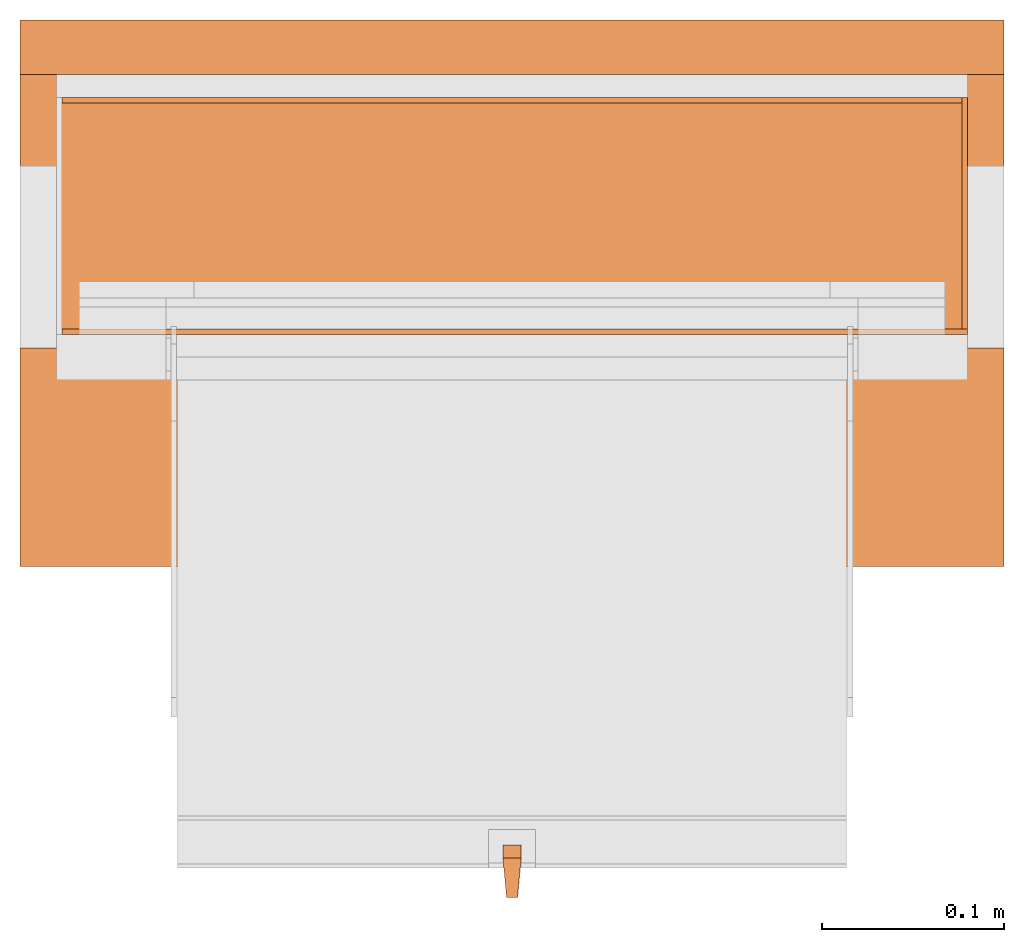
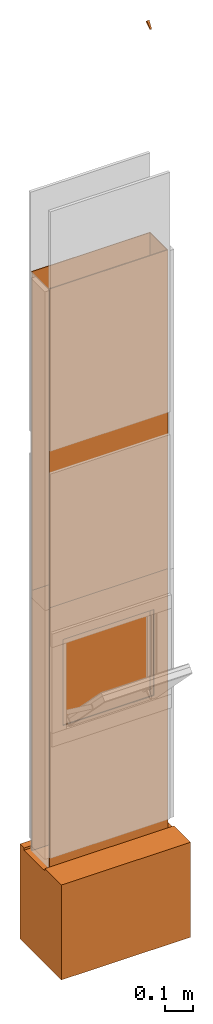
# One storey, part 3 of 3: 8 proxies, 1 opening.
"""IFC2X3 building model written with IfcOpenShell, lengths in metres."""

from ifc_helpers import new_model, entity, si_unit, converted_unit, derived_unit, money_unit, direction, frame, origin_with_axes, origin_2d_with_axis, place, context, subcontext, project, spatial, polyline, rectangle, outline, extrude, boolean, faceted_brep, source, transform, mapped, material, type_object, element, save


model = new_model("IFC2X3")

# Units and contexts
model_context = context("Model", 3, precision=1e-05, world=origin_with_axes(), true_north=direction((0.0, 1.0)))
plan_context = context("Plan", 3, precision=1e-05, world=origin_with_axes(), true_north=direction((0.0, 1.0)))
body_context = subcontext(model_context, "Body", "Model", "MODEL_VIEW")
ifc_project = project(units=[si_unit("LENGTHUNIT", "METRE"), si_unit("AREAUNIT", "SQUARE_METRE"), si_unit("VOLUMEUNIT", "CUBIC_METRE"), converted_unit("PLANEANGLEUNIT", "DEGREE", entity("IfcPlaneAngleMeasure", 0.0174532925199), si_unit("PLANEANGLEUNIT", "RADIAN"), dimensions=[0, 0, 0, 0, 0, 0, 0]), si_unit("SOLIDANGLEUNIT", "STERADIAN"), money_unit("CHF"), converted_unit("TIMEUNIT", "Year", entity("IfcTimeMeasure", 31556926.0), si_unit("TIMEUNIT", "SECOND"), dimensions=[0, 0, 1, 0, 0, 0, 0]), si_unit("MASSUNIT", "GRAM", prefix="KILO"), si_unit("THERMODYNAMICTEMPERATUREUNIT", "DEGREE_CELSIUS"), si_unit("LUMINOUSINTENSITYUNIT", "LUMEN"), si_unit("ENERGYUNIT", "JOULE", prefix="MEGA"), derived_unit("THERMALCONDUCTANCEUNIT", [(si_unit("POWERUNIT", "WATT"), 1), (si_unit("LENGTHUNIT", "METRE"), -1), (si_unit("THERMODYNAMICTEMPERATUREUNIT", "KELVIN"), -1)]), derived_unit("SPECIFICHEATCAPACITYUNIT", [(si_unit("ENERGYUNIT", "JOULE"), 1), (si_unit("MASSUNIT", "GRAM", prefix="KILO"), -1), (si_unit("THERMODYNAMICTEMPERATUREUNIT", "KELVIN"), -1)]), derived_unit("MASSDENSITYUNIT", [(si_unit("MASSUNIT", "GRAM", prefix="KILO"), 1), (si_unit("VOLUMEUNIT", "CUBIC_METRE"), -1)])], contexts=[model_context, plan_context])

# Site, building, storey
site_placement = place(None, origin_with_axes())
site = spatial("IfcSite", under=ifc_project, at=site_placement, CompositionType="ELEMENT")
building_placement = place(site_placement, origin_with_axes())
building = spatial("IfcBuilding", under=site, at=building_placement, CompositionType="ELEMENT")
storey_placement = place(building_placement, origin_with_axes())
storey = spatial("IfcBuildingStorey", under=building, at=storey_placement, Name="EG00", CompositionType="ELEMENT", Elevation=0.0)

# Proxies
ifc_material_1 = material(Name="Metall, Stahl")
building_element_proxy_type_1 = type_object("IfcBuildingElementProxyType", Name="Metall, Stahl 3", PredefinedType="NOTDEFINED")
proxy_1_placement = place(storey_placement, frame((2.05655524907, -3.88878861887, 1.15), z_axis=(0.0, 0.0, 1.0), x_axis=(0.0, 1.0, 0.0)))
element("IfcBuildingElementProxy", 1, at=proxy_1_placement, inside=storey, type_object=building_element_proxy_type_1, material=ifc_material_1, Name="Wand-007", context=body_context, shape_type="CSG", body=[
    boolean("DIFFERENCE", extrude(outline(polyline([(0.0, 0.0), (0.13, 0.0), (0.13, 0.003), (0.0, 0.003), (0.0, 0.0)])), origin_with_axes(), (0.0, 0.0, 1.0), 1.41), faceted_brep([(0.003, 0.0, 0.0), (0.003, 0.0, 1.41), (0.0, 0.0, 1.41), (0.0, 0.0, 0.0), (0.003, 0.003, 1.41), (0.003, 0.003, 0.0), (0.0, 0.003, 1.41), (0.0, 0.003, 0.0)], [[[0, 1, 2, 3]], [[4, 1, 0, 5]], [[1, 4, 6, 2]], [[6, 7, 3, 2]], [[5, 0, 3, 7]], [[4, 5, 7, 6]]])),
])
proxy_2_placement = place(storey_placement, frame((1.55655524907, -3.88878861887, 1.15), z_axis=(0.0, 0.0, 1.0), x_axis=(1.0, 0.0, 0.0)))
element("IfcBuildingElementProxy", 2, at=proxy_2_placement, inside=storey, type_object=building_element_proxy_type_1, material=ifc_material_1, Name="Wand-006", context=body_context, shape_type="CSG", body=[
    boolean("DIFFERENCE", extrude(outline(polyline([(0.0, 0.0), (0.5, 0.0), (0.5, 0.003), (0.0, 0.003), (0.0, 0.0)])), origin_with_axes(), (0.0, 0.0, 1.0), 1.41), faceted_brep([(0.003, 0.0, 1.41), (0.003, 0.003, 1.41), (0.0, 0.003, 1.41), (0.0, 0.0, 1.41), (0.003, 0.003, 0.0), (0.003, 0.0, 0.0), (0.0, 0.003, 0.0), (0.0, 0.0, 0.0)], [[[0, 1, 2, 3]], [[4, 1, 0, 5]], [[1, 4, 6, 2]], [[2, 6, 7, 3]], [[5, 0, 3, 7]], [[4, 5, 7, 6]]])),
])
proxy_3_placement = place(storey_placement, frame((2.05655524907, -3.75878861887, 0.0), z_axis=(0.0, 0.0, 1.0), x_axis=(-1.0, 0.0, 0.0)))
element("IfcBuildingElementProxy", 3, at=proxy_3_placement, inside=storey, type_object=building_element_proxy_type_1, material=ifc_material_1, Name="Wand-008", context=body_context, shape_type="CSG", body=[
    boolean("DIFFERENCE", boolean("DIFFERENCE", extrude(outline(polyline([(0.0, 0.0), (0.5, 0.0), (0.5, 0.003), (0.0, 0.003), (0.0, 0.0)])), origin_with_axes(), (0.0, 0.0, 1.0), 1.15), faceted_brep([(0.497, 0.003, 1.15), (0.497, 0.0, 1.15), (0.5, 0.0, 1.15), (0.5, 0.003, 1.15), (0.497, 0.0, 0.0), (0.497, 0.003, 0.0), (0.5, 0.0, 0.0), (0.5, 0.003, 0.0)], [[[0, 1, 2, 3]], [[4, 1, 0, 5]], [[1, 4, 6, 2]], [[2, 6, 7, 3]], [[5, 0, 3, 7]], [[4, 5, 7, 6]]])), faceted_brep([(0.003, 0.0, 0.0), (0.003, 0.0, 1.15), (0.0, 0.0, 1.15), (0.0, 0.0, 0.0), (0.003, 0.003, 1.15), (0.003, 0.003, 0.0), (0.0, 0.003, 1.15), (0.0, 0.003, 0.0)], [[[0, 1, 2, 3]], [[4, 1, 0, 5]], [[1, 4, 6, 2]], [[6, 7, 3, 2]], [[5, 0, 3, 7]], [[4, 5, 7, 6]]])),
])
proxy_4_placement = place(storey_placement, frame((2.05655524907, -3.88878861887, 0.0), z_axis=(0.0, 0.0, 1.0), x_axis=(0.0, 1.0, 0.0)))
element("IfcBuildingElementProxy", 4, at=proxy_4_placement, inside=storey, type_object=building_element_proxy_type_1, material=ifc_material_1, Name="Wand-007", context=body_context, shape_type="CSG", body=[
    boolean("DIFFERENCE", extrude(outline(polyline([(0.0, 0.0), (0.13, 0.0), (0.13, 0.003), (0.0, 0.003), (0.0, 0.0)])), origin_with_axes(), (0.0, 0.0, 1.0), 1.15), faceted_brep([(0.003, 0.0, 0.0), (0.003, 0.0, 1.15), (0.0, 0.0, 1.15), (0.0, 0.0, 0.0), (0.003, 0.003, 1.15), (0.003, 0.003, 0.0), (0.0, 0.003, 1.15), (0.0, 0.003, 0.0)], [[[0, 1, 2, 3]], [[4, 1, 0, 5]], [[1, 4, 6, 2]], [[6, 7, 3, 2]], [[5, 0, 3, 7]], [[4, 5, 7, 6]]])),
])

# Proxy, opening
proxy_5_placement = place(storey_placement, frame((1.55655524907, -3.88878861887, 0.0), z_axis=(0.0, 0.0, 1.0), x_axis=(1.0, 0.0, 0.0)))
proxy_5 = element("IfcBuildingElementProxy", 5, at=proxy_5_placement, inside=storey, type_object=building_element_proxy_type_1, material=ifc_material_1, Name="Wand-006", context=body_context, shape_type="CSG", body=[
    boolean("DIFFERENCE", extrude(outline(polyline([(0.0, 0.0), (0.5, 0.0), (0.5, 0.003), (0.0, 0.003), (0.0, 0.0)])), origin_with_axes(), (0.0, 0.0, 1.0), 1.15), faceted_brep([(0.003, 0.0, 1.15), (0.003, 0.003, 1.15), (0.0, 0.003, 1.15), (0.0, 0.0, 1.15), (0.003, 0.003, 0.0), (0.003, 0.0, 0.0), (0.0, 0.003, 0.0), (0.0, 0.0, 0.0)], [[[0, 1, 2, 3]], [[4, 1, 0, 5]], [[1, 4, 6, 2]], [[2, 6, 7, 3]], [[5, 0, 3, 7]], [[4, 5, 7, 6]]])),
])
opening_placement = place(proxy_5_placement, frame((-1.55655524907, 3.88878861887, 0.0), z_axis=(0.0, 0.0, 1.0), x_axis=(1.0, 0.0, 0.0)))
element("IfcOpeningElement", 6, at=opening_placement, cuts=proxy_5, Name="014", context=body_context, shape_type="SweptSolid", body=[
    extrude(rectangle(XDim=0.38, YDim=0.38, at=origin_2d_with_axis()), frame((1.80655524907, -3.91378861887, 0.8), z_axis=(0.0, -1.0, 0.0), x_axis=(1.0, 0.0, 0.0)), (0.0, 0.0, -1.0), 0.031),
])

# Proxies
proxy_6_placement = place(storey_placement, frame((2.05655524907, -3.75878861887, 1.15), z_axis=(0.0, 0.0, 1.0), x_axis=(-1.0, 0.0, 0.0)))
element("IfcBuildingElementProxy", 7, at=proxy_6_placement, inside=storey, type_object=building_element_proxy_type_1, material=ifc_material_1, Name="Wand-008", context=body_context, shape_type="CSG", body=[
    boolean("DIFFERENCE", boolean("DIFFERENCE", extrude(outline(polyline([(0.0, 0.0), (0.5, 0.0), (0.5, 0.003), (0.0, 0.003), (0.0, 0.0)])), origin_with_axes(), (0.0, 0.0, 1.0), 1.41), faceted_brep([(0.497, 0.003, 1.41), (0.497, 0.0, 1.41), (0.5, 0.0, 1.41), (0.5, 0.003, 1.41), (0.497, 0.0, 0.0), (0.497, 0.003, 0.0), (0.5, 0.0, 0.0), (0.5, 0.003, 0.0)], [[[0, 1, 2, 3]], [[4, 1, 0, 5]], [[1, 4, 6, 2]], [[2, 6, 7, 3]], [[5, 0, 3, 7]], [[4, 5, 7, 6]]])), faceted_brep([(0.003, 0.0, 0.0), (0.003, 0.0, 1.41), (0.0, 0.0, 1.41), (0.0, 0.0, 0.0), (0.003, 0.003, 1.41), (0.003, 0.003, 0.0), (0.0, 0.003, 1.41), (0.0, 0.003, 0.0)], [[[0, 1, 2, 3]], [[4, 1, 0, 5]], [[1, 4, 6, 2]], [[6, 7, 3, 2]], [[5, 0, 3, 7]], [[4, 5, 7, 6]]])),
])
ifc_material_2 = material(Name="Luft, horizontal")
building_element_proxy_type_2 = type_object("IfcBuildingElementProxyType", Name="Luft, horizontal 420", PredefinedType="NOTDEFINED")
proxy_7_placement = place(storey_placement, frame((1.53655524907, -4.01628861887, 0.01), z_axis=(0.0, 0.0, 1.0), x_axis=(1.0, 0.0, 0.0)))
element("IfcBuildingElementProxy", 8, at=proxy_7_placement, inside=storey, type_object=building_element_proxy_type_2, material=ifc_material_2, Name="Decke-007", context=body_context, shape_type="CSG", body=[
    boolean("DIFFERENCE", extrude(outline(polyline([(0.0, 0.0), (0.54, 0.0), (0.54, 0.3), (0.0, 0.3), (0.0, 0.0)])), frame((0.0, 0.0, -0.42), z_axis=(0.0, 0.0, 1.0), x_axis=(1.0, 0.0, 0.0)), (0.0, 0.0, 1.0), 0.42), faceted_brep([(0.54, 0.12, -0.01), (0.54, 0.27, -0.01), (0.54, 0.27, 0.0), (0.54, 0.12, 0.0), (0.0, 0.12, -0.01), (0.0, 0.27, -0.01), (0.0, 0.27, 0.0), (0.0, 0.12, 0.0)], [[[0, 1, 2, 3]], [[1, 0, 4, 5]], [[6, 2, 1, 5]], [[7, 3, 2, 6]], [[0, 3, 7, 4]], [[4, 7, 6, 5]]])),
])
ifc_material_3 = material(Name="Metall, Aluminium")
building_element_proxy_type_3 = type_object("IfcBuildingElementProxyType", Name="Metall, Aluminium", PredefinedType="NOTDEFINED")
shared_shape = source(origin_with_axes(), body_context, "Body", "Brep", [
    faceted_brep([(16.3891379247, -3.43334637562, 1.097), (16.3891379247, -3.44334637562, 1.097), (16.3921379247, -3.43534637562, 1.13058255688), (16.3991379247, -3.43334637562, 1.097), (16.3991379247, -3.44334637562, 1.097), (16.3921379247, -3.44134637562, 1.13058255688), (16.3961379247, -3.43523159518, 1.13058255688), (16.3961379247, -3.4414517679, 1.13058255688)], [[[0, 1, 2]], [[1, 0, 3, 4]], [[1, 5, 2]], [[0, 2, 3]], [[4, 3, 6]], [[5, 1, 4]], [[2, 5, 7]], [[3, 2, 6]], [[6, 7, 4]], [[7, 5, 4]], [[2, 7, 6]]]),
])
proxy_8_placement = place(storey_placement, frame((5.24490162469, -14.8694200011, 16.3044423362), z_axis=(0.0, -0.713898265506, -0.700249431636), x_axis=(0.0, 0.700249431636, -0.713898265506)))
element("IfcBuildingElementProxy", 9, at=proxy_8_placement, inside=storey, type_object=building_element_proxy_type_3, material=ifc_material_3, Name="Wand-008", context=body_context, shape_type="MappedRepresentation", body=[
    mapped(shared_shape, transform((0.0, 0.0, 0.0))),
])

save(model, "model.ifc")
